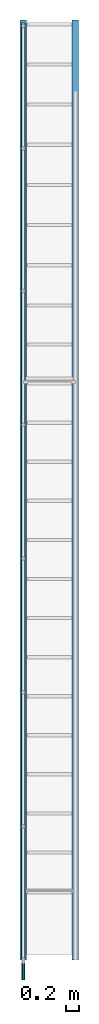
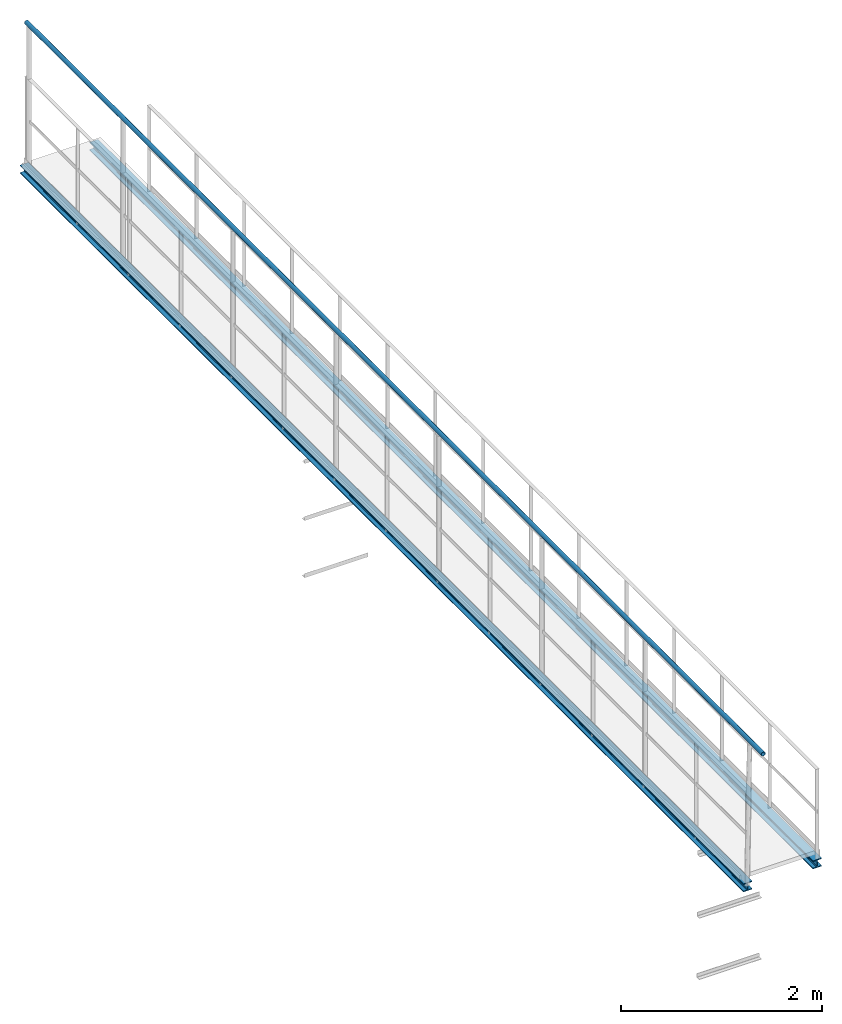
# One storey, part 2 of 6: 3 beams.
"""IFC2X3 building model written with IfcOpenShell, lengths in metres."""

from ifc_helpers import new_model, entity, si_unit, converted_unit, derived_unit, direction, frame, frame_2d, origin, origin_2d_with_axis, place, context, subcontext, project, spatial, hollow_circle, i_section, extrude, material, type_object, element, save


model = new_model("IFC2X3")

# Units and contexts
model_context = context("Model", 3, precision=1e-05, world=origin(), true_north=direction((6.123233995736766e-17, 1.0)))
body_context = subcontext(model_context, "Body", "Model", "MODEL_VIEW")
ifc_project = project(units=[si_unit("LENGTHUNIT", "METRE"), converted_unit("PLANEANGLEUNIT", "DEGREE", entity("IfcPlaneAngleMeasure", 0.017453292519943278), si_unit("PLANEANGLEUNIT", "RADIAN"), dimensions=[0, 0, 0, 0, 0, 0, 0]), si_unit("AREAUNIT", "SQUARE_METRE"), derived_unit("THERMALTRANSMITTANCEUNIT", [(si_unit("MASSUNIT", "GRAM", prefix="KILO"), 1), (si_unit("THERMODYNAMICTEMPERATUREUNIT", "KELVIN"), -1), (si_unit("TIMEUNIT", "SECOND"), -3)])], contexts=[model_context])

# Site, building, storey
site_placement = place(None, origin())
site = spatial("IfcSite", under=ifc_project, at=site_placement, CompositionType="ELEMENT")
building_placement = place(site_placement, origin())
building = spatial("IfcBuilding", under=site, at=building_placement, CompositionType="ELEMENT")
storey_placement = place(building_placement, frame((0.0, 0.0, 8.8)))
storey = spatial("IfcBuildingStorey", under=building, at=storey_placement, Name="Piso 2.3", CompositionType="ELEMENT", Elevation=8.8)

# Beams
ifc_material = material(Name="Metal - Steel - 345 MPa")
beam_type_1 = type_object("IfcBeamType", PredefinedType="BEAM")
beam_1_placement = place(storey_placement, frame((3.706697135192124, -4.326477767563769, 0.0), z_axis=(0.0, 0.0, 1.0), x_axis=(0.0, 1.0, 0.0)))
element("IfcBeam", 1, at=beam_1_placement, inside=storey, type_object=beam_type_1, material=ifc_material, context=body_context, shape_type="SweptSolid", body=[
    extrude(i_section(OverallWidth=0.1, OverallDepth=0.1, WebThickness=0.00600000000000026, FlangeThickness=0.010000000000000975, FilletRadius=0.012000000000000299, at=frame_2d((2.706168622523819e-15, -8.118505867571457e-16), x_axis=(0.0, 1.0))), frame((-0.039676069535057264, 0.0, 0.0), z_axis=(1.0, 0.0, 0.0), x_axis=(0.0, 0.0, -1.0)), (0.0, 0.0, 1.0), 14.431),
])
beam_2_placement = place(storey_placement, frame((4.506697135192172, -3.796477767563772, 0.0), z_axis=(0.0, 0.0, 1.0), x_axis=(0.0, 1.0, 0.0)))
element("IfcBeam", 2, at=beam_2_placement, inside=storey, type_object=beam_type_1, material=ifc_material, context=body_context, shape_type="SweptSolid", body=[
    extrude(i_section(OverallWidth=0.1, OverallDepth=0.1, WebThickness=0.00600000000000026, FlangeThickness=0.010000000000000975, FilletRadius=0.012000000000000299, at=frame_2d((2.706168622523819e-15, 1.3530843112619095e-15), x_axis=(0.0, 1.0))), frame((-0.5696760695350538, 0.0, 0.0), z_axis=(1.0, 0.0, 0.0), x_axis=(0.0, 0.0, -1.0)), (0.0, 0.0, 1.0), 14.430999999999994),
])
beam_type_2 = type_object("IfcBeamType", Name="Circular Hollow Sections:TRON50x2.5", PredefinedType="BEAM")
beam_3_placement = place(storey_placement, frame((3.7066971351921425, 6.663605515165065, 0.0), z_axis=(0.0, 0.0, 1.0), x_axis=(0.0, -1.0, 0.0)))
element("IfcBeam", 3, at=beam_3_placement, inside=storey, type_object=beam_type_2, material=ifc_material, Name="Circular Hollow Sections:TRON50x2.5", ObjectType="Circular Hollow Sections:TRON50x2.5", context=body_context, shape_type="SweptSolid", body=[
    extrude(hollow_circle(Radius=0.025000000000000813, WallThickness=0.0025000000000008106, at=origin_2d_with_axis()), frame((-3.3563468673014594, 0.0, 1.8), z_axis=(1.0, 0.0, 0.0), x_axis=(0.0, 1.0, 0.0)), (0.0, 0.0, 1.0), 14.69456457820105),
])

save(model, "model.ifc")
